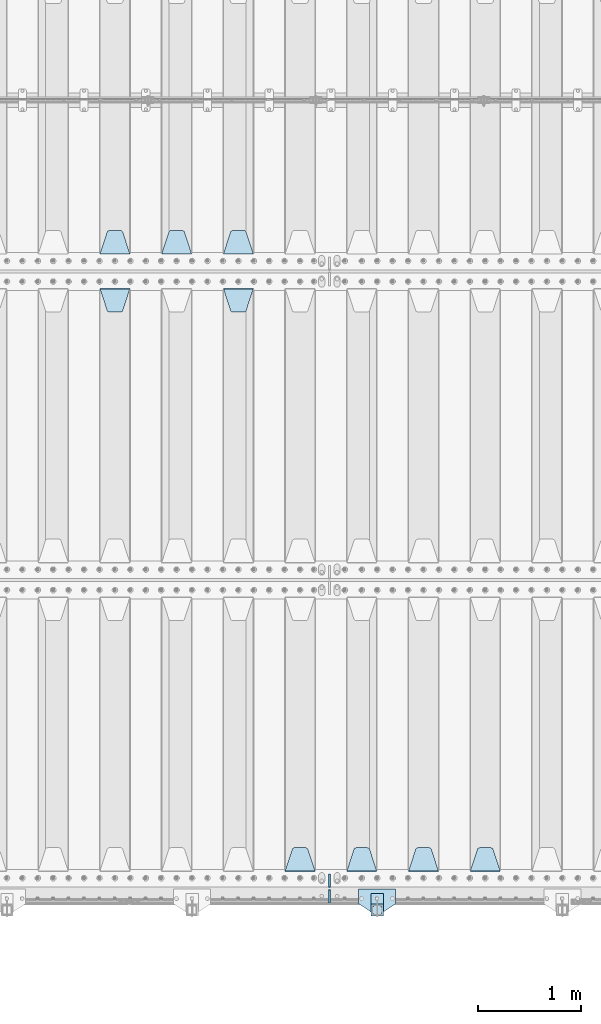
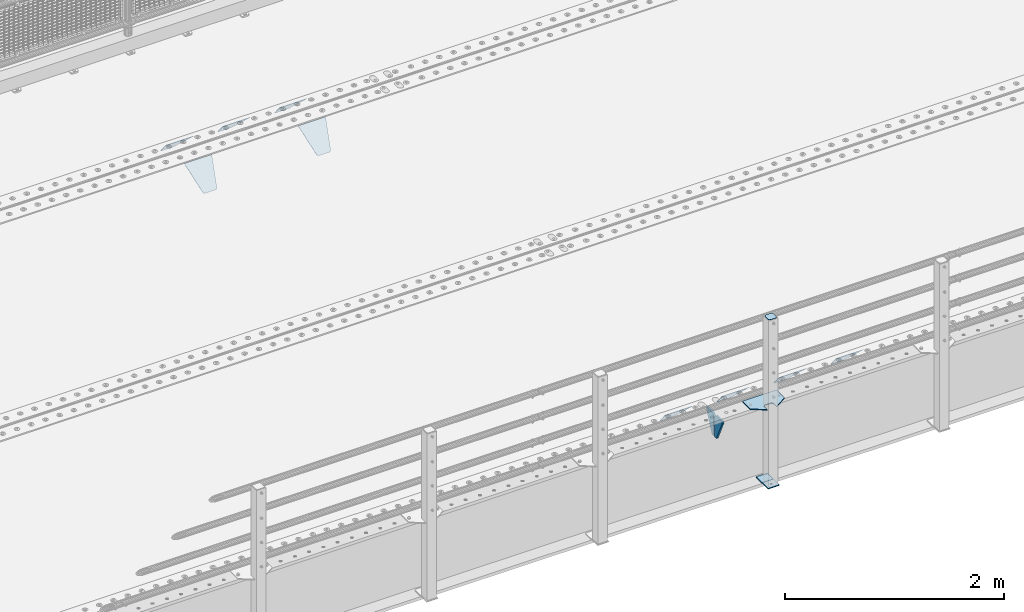
# One storey, part 220 of 270: 15 plates.
"""IFC2X3 building model written with IfcOpenShell, lengths in millimetres."""

from ifc_helpers import new_model, si_unit, frame, origin_with_axes, place, context, subcontext, project, spatial, faceted_brep, material, type_object, element, save


model = new_model("IFC2X3")

# Units and contexts
model_context = context("Model", 3, precision=1e-05, world=origin_with_axes())
body_context = subcontext(model_context, "Body", "Model", "MODEL_VIEW")
ifc_project = project(units=[si_unit("LENGTHUNIT", "METRE", prefix="MILLI"), si_unit("AREAUNIT", "SQUARE_METRE"), si_unit("VOLUMEUNIT", "CUBIC_METRE"), si_unit("MASSUNIT", "GRAM", prefix="KILO"), si_unit("TIMEUNIT", "SECOND"), si_unit("PLANEANGLEUNIT", "RADIAN"), si_unit("SOLIDANGLEUNIT", "STERADIAN"), si_unit("THERMODYNAMICTEMPERATUREUNIT", "DEGREE_CELSIUS"), si_unit("LUMINOUSINTENSITYUNIT", "LUMEN")], contexts=[model_context])

# Site, building, storey
site_placement = place(None, origin_with_axes())
site = spatial("IfcSite", under=ifc_project, at=site_placement, CompositionType="ELEMENT")
building_placement = place(site_placement, origin_with_axes())
building = spatial("IfcBuilding", under=site, at=building_placement, Name="Standard", CompositionType="ELEMENT")
storey_placement = place(building_placement, origin_with_axes())
storey = spatial("IfcBuildingStorey", under=building, at=storey_placement, Name="Undefined", CompositionType="ELEMENT", Elevation=0.0)

# Plates
ifc_material_1 = material(Name="STEEL/S355J2")
plate_type_1 = type_object("IfcPlateType", PredefinedType="NOTDEFINED")
plate_1_placement = place(storey_placement, frame((7930.0, -24005.0, 5.00000000004911), z_axis=(0.0, -1.0, 0.0), x_axis=(-1.0, 0.0, 0.0)))
element("IfcPlate", 1, at=plate_1_placement, inside=storey, type_object=plate_type_1, material=ifc_material_1, context=body_context, shape_type="Brep", body=[
    faceted_brep([(0.0, -5.0, 0.0), (2.31396552408114e-06, -5.0, 145.0), (2.31396552408114e-06, 5.0, 145.0), (0.0, 5.0, 0.0), (130.0, -5.0, 230.0), (130.0, 5.0, 230.0), (130.0, -5.0, 180.0), (130.0, 5.0, 180.0), (130.48036798992, -5.0, 175.122741949597), (130.48036798992, 5.0, 175.122741949597), (131.903011687216, -5.0, 170.432914190873), (131.903011687216, 5.0, 170.432914190873), (134.213259692435, -5.0, 166.11074417451), (134.213259692435, 5.0, 166.11074417451), (137.322330470335, -5.0, 162.322330470337), (137.322330470335, 5.0, 162.322330470337), (141.110744174512, -5.0, 159.213259692437), (141.110744174512, 5.0, 159.213259692437), (145.432914190871, -5.0, 156.903011687218), (145.432914190871, 5.0, 156.903011687218), (150.122741949595, -5.0, 155.48036798992), (150.122741949595, 5.0, 155.48036798992), (155.0, -5.0, 155.0), (155.0, 5.0, 155.0), (205.0, -5.0, 155.0), (205.0, 5.0, 155.0), (209.877258050405, -5.0, 155.48036798992), (209.877258050405, 5.0, 155.48036798992), (214.567085809129, -5.0, 156.903011687218), (214.567085809129, 5.0, 156.903011687218), (218.889255825488, -5.0, 159.213259692437), (218.889255825488, 5.0, 159.213259692437), (222.677669529665, -5.0, 162.322330470337), (222.677669529665, 5.0, 162.322330470337), (225.786740307565, -5.0, 166.11074417451), (225.786740307565, 5.0, 166.11074417451), (228.096988312784, -5.0, 170.432914190873), (228.096988312784, 5.0, 170.432914190873), (229.51963201008, -5.0, 175.122741949597), (229.51963201008, 5.0, 175.122741949597), (230.0, -5.0, 180.0), (230.0, 5.0, 180.0), (230.0, -5.0, 230.0), (230.0, 5.0, 230.0), (360.0, -5.0, 145.0), (360.0, 5.0, 145.0), (360.0, -5.0, -7.27595761418343e-12), (360.0, 5.0, -7.27595761418343e-12)], [[[0, 1, 2, 3]], [[1, 4, 5, 2]], [[4, 6, 7, 5]], [[6, 8, 9, 7]], [[8, 10, 11, 9]], [[10, 12, 13, 11]], [[12, 14, 15, 13]], [[14, 16, 17, 15]], [[16, 18, 19, 17]], [[18, 20, 21, 19]], [[20, 22, 23, 21]], [[22, 24, 25, 23]], [[24, 26, 27, 25]], [[26, 28, 29, 27]], [[28, 30, 31, 29]], [[30, 32, 33, 31]], [[32, 34, 35, 33]], [[34, 36, 37, 35]], [[36, 38, 39, 37]], [[38, 40, 41, 39]], [[40, 42, 43, 41]], [[42, 44, 45, 43]], [[44, 46, 47, 45]], [[46, 0, 3, 47]], [[5, 7, 9, 11, 13, 15, 17, 19, 21, 23, 25, 27, 29, 31, 33, 35, 37, 39, 41, 43, 45, 47, 3, 2]], [[46, 44, 42, 40, 38, 36, 34, 32, 30, 28, 26, 24, 22, 20, 18, 16, 14, 12, 10, 8, 6, 4, 1, 0]]]),
])
plate_type_2 = type_object("IfcPlateType", PredefinedType="NOTDEFINED")
plate_2_placement = place(storey_placement, frame((7809.99999999986, -24050.0000000002, -850.000000000002), z_axis=(0.0, -1.0, 0.0), x_axis=(-1.0, 0.0, 0.0)))
element("IfcPlate", 2, at=plate_2_placement, inside=storey, type_object=plate_type_2, material=ifc_material_1, context=body_context, shape_type="Brep", body=[
    faceted_brep([(53.6360389691836, -5.0, 176.363961030471), (53.6360389691836, 5.0, 176.363961030471), (59.9999999998618, 5.0, 178.999999999793), (59.9999999998618, -5.0, 178.999999999793), (66.3639610305399, 5.0, 176.363961030471), (66.3639610305399, -5.0, 176.363961030471), (68.9999999998618, 5.0, 169.999999999793), (68.9999999998618, -5.0, 169.999999999793), (66.3639610305399, 5.0, 163.636038969114), (66.3639610305399, -5.0, 163.636038969114), (59.9999999998618, 5.0, 160.999999999793), (59.9999999998618, -5.0, 160.999999999793), (53.6360389691836, 5.0, 163.636038969114), (53.6360389691836, -5.0, 163.636038969114), (50.9999999998618, 5.0, 169.999999999793), (50.9999999998618, -5.0, 169.999999999793), (120.0, -5.0, 0.0), (120.0, -5.0, 220.0), (0.0, -5.0, 220.0), (0.0, -5.0, 0.0), (0.0, 5.0, 0.0), (120.0, 5.0, 0.0), (120.0, 5.0, 220.0), (0.0, 5.0, 220.0)], [[[0, 1, 2, 3]], [[3, 2, 4, 5]], [[5, 4, 6, 7]], [[7, 6, 8, 9]], [[9, 8, 10, 11]], [[11, 10, 12, 13]], [[13, 12, 14, 15]], [[15, 14, 1, 0]], [[16, 17, 18, 19], [11, 13, 15, 0, 3, 5, 7, 9]], [[16, 19, 20, 21]], [[17, 16, 21, 22]], [[18, 17, 22, 23]], [[19, 18, 23, 20]], [[22, 21, 20, 23], [2, 1, 14, 12, 10, 8, 6, 4]]]),
])
plate_type_3 = type_object("IfcPlateType", PredefinedType="NOTDEFINED")
plate_3_placement = place(storey_placement, frame((7705.99999999987, -24166.0000000002, 1012.50000000001), z_axis=(0.0, -1.0, 0.0), x_axis=(1.0, 0.0, 0.0)))
element("IfcPlate", 3, at=plate_3_placement, inside=storey, type_object=plate_type_3, material=ifc_material_1, context=body_context, shape_type="Brep", body=[
    faceted_brep([(0.0, -2.5, 19.0), (0.0, -2.5, 69.0), (0.0, 2.5, 69.0), (0.0, 2.5, 19.0), (0.476369668544066, -2.5, 73.2278977451697), (0.476369668544066, 2.5, 73.2278977451697), (1.88159150985302, -2.5, 77.2437910432327), (1.88159150985302, 2.5, 77.2437910432327), (4.14520183310742, -2.5, 80.8463062353167), (4.14520183310742, 2.5, 80.8463062353167), (7.15369376468516, -2.5, 83.8547981668926), (7.15369376468516, 2.5, 83.8547981668926), (10.7562089567655, -2.5, 86.1184084901452), (10.7562089567655, 2.5, 86.1184084901452), (14.7721022548285, -2.5, 87.5236303314541), (14.7721022548285, 2.5, 87.5236303314541), (19.0, -2.5, 88.0), (19.0, 2.5, 88.0), (69.0, -2.5, 88.0), (69.0, 2.5, 88.0), (73.2278977451715, -2.5, 87.5236303314541), (73.2278977451715, 2.5, 87.5236303314541), (77.2437910432345, -2.5, 86.1184084901452), (77.2437910432345, 2.5, 86.1184084901452), (80.8463062353148, -2.5, 83.8547981668926), (80.8463062353148, 2.5, 83.8547981668926), (83.8547981668926, -2.5, 80.8463062353167), (83.8547981668926, 2.5, 80.8463062353167), (86.118408490147, -2.5, 77.2437910432345), (86.118408490147, 2.5, 77.2437910432345), (87.5236303314559, -2.5, 73.2278977451697), (87.5236303314559, 2.5, 73.2278977451697), (88.0, -2.5, 69.0), (88.0, 2.5, 69.0), (88.0, -2.5, 19.0), (88.0, 2.5, 19.0), (87.5236303314559, -2.5, 14.7721022548303), (87.5236303314559, 2.5, 14.7721022548303), (86.118408490147, -2.5, 10.7562089567673), (86.118408490147, 2.5, 10.7562089567673), (83.8547981668926, -2.5, 7.15369376468334), (83.8547981668926, 2.5, 7.15369376468334), (80.8463062353148, -2.5, 4.14520183310742), (80.8463062353148, 2.5, 4.14520183310742), (77.2437910432345, -2.5, 1.88159150985484), (77.2437910432345, 2.5, 1.88159150985484), (73.2278977451715, -2.5, 0.476369668545885), (73.2278977451715, 2.5, 0.476369668545885), (69.0, -2.5, 0.0), (69.0, 2.5, 0.0), (19.0, -2.5, 0.0), (19.0, 2.5, 0.0), (14.7721022548285, -2.5, 0.476369668545885), (14.7721022548285, 2.5, 0.476369668545885), (10.7562089567655, -2.5, 1.88159150985484), (10.7562089567655, 2.5, 1.88159150985484), (7.15369376468516, -2.5, 4.14520183310742), (7.15369376468516, 2.5, 4.14520183310742), (4.14520183310742, -2.5, 7.15369376468334), (4.14520183310742, 2.5, 7.15369376468334), (1.88159150985302, -2.5, 10.7562089567673), (1.88159150985302, 2.5, 10.7562089567673), (0.476369668544066, -2.5, 14.7721022548303), (0.476369668544066, 2.5, 14.7721022548303)], [[[0, 1, 2, 3]], [[1, 4, 5, 2]], [[4, 6, 7, 5]], [[6, 8, 9, 7]], [[8, 10, 11, 9]], [[10, 12, 13, 11]], [[12, 14, 15, 13]], [[14, 16, 17, 15]], [[16, 18, 19, 17]], [[18, 20, 21, 19]], [[20, 22, 23, 21]], [[22, 24, 25, 23]], [[24, 26, 27, 25]], [[26, 28, 29, 27]], [[28, 30, 31, 29]], [[30, 32, 33, 31]], [[32, 34, 35, 33]], [[34, 36, 37, 35]], [[36, 38, 39, 37]], [[38, 40, 41, 39]], [[40, 42, 43, 41]], [[42, 44, 45, 43]], [[44, 46, 47, 45]], [[46, 48, 49, 47]], [[48, 50, 51, 49]], [[50, 52, 53, 51]], [[52, 54, 55, 53]], [[54, 56, 57, 55]], [[56, 58, 59, 57]], [[58, 60, 61, 59]], [[60, 62, 63, 61]], [[62, 0, 3, 63]], [[5, 7, 9, 11, 13, 15, 17, 19, 21, 23, 25, 27, 29, 31, 33, 35, 37, 39, 41, 43, 45, 47, 49, 51, 53, 55, 57, 59, 61, 63, 3, 2]], [[62, 60, 58, 56, 54, 52, 50, 48, 46, 44, 42, 40, 38, 36, 34, 32, 30, 28, 26, 24, 22, 20, 18, 16, 14, 12, 10, 8, 6, 4, 1, 0]]]),
])
plate_type_4 = type_object("IfcPlateType", PredefinedType="NOTDEFINED")
plate_4_placement = place(storey_placement, frame((7809.99999999986, -24050.0000000002, -857.500000000002), z_axis=(0.0, -1.0, 0.0), x_axis=(-1.0, 0.0, 0.0)))
element("IfcPlate", 4, at=plate_4_placement, inside=storey, type_object=plate_type_4, material=ifc_material_1, context=body_context, shape_type="Brep", body=[
    faceted_brep([(0.0, -2.5, 0.0), (0.0, -2.5, 100.0), (0.0, 2.5, 100.0), (0.0, 2.5, 0.0), (120.0, -2.5, 100.0), (120.0, 2.5, 100.0), (120.0, -2.5, 0.0), (120.0, 2.5, 0.0)], [[[0, 1, 2, 3]], [[1, 4, 5, 2]], [[4, 6, 7, 5]], [[6, 0, 3, 7]], [[5, 7, 3, 2]], [[6, 4, 1, 0]]]),
])
ifc_material_2 = material(Name="STEEL/S355N")
plate_type_5 = type_object("IfcPlateType", PredefinedType="NOTDEFINED")
plate_5_placement = place(storey_placement, frame((6545.0, -17831.767766953, -1.76776695296758), z_axis=(0.0, 0.707106781186547, -0.707106781186548), x_axis=(-1.0, 0.0, 0.0)))
element("IfcPlate", 5, at=plate_5_placement, inside=storey, type_object=plate_type_5, material=ifc_material_2, context=body_context, shape_type="Brep", body=[
    faceted_brep([(0.0, -2.5, 0.0), (69.345504679477, -2.5, 300.171731424831), (69.345504679477, 2.5, 300.171731424831), (0.0, 2.5, 0.0), (70.9274061199576, -2.5, 304.8974424154), (70.9274061199576, 2.5, 304.8974424154), (73.3818627772307, -2.49999999999818, 309.234538108527), (73.3818627772307, 2.50000000000182, 309.234538108527), (76.6187032999551, -2.5, 313.023683126103), (76.6187032999551, 2.5, 313.023683126103), (80.5190132704993, -2.5, 316.125672595372), (80.5190132704993, 2.50000000000182, 316.125672595372), (84.9395038596849, -2.49999999999818, 318.426546230476), (84.9395038596849, 2.5, 318.426546230476), (89.7177759439219, -2.49999999999818, 319.841774983275), (89.7177759439219, 2.50000000000182, 319.841774983275), (94.678286292652, -2.5, 320.319366455078), (94.678286292652, 2.5, 320.319366455078), (195.321713707348, -2.5, 320.319366455078), (195.321713707348, 2.5, 320.319366455078), (200.282224056078, -2.49999999999818, 319.841774983275), (200.282224056078, 2.50000000000182, 319.841774983275), (205.060496140315, -2.5, 318.426546230476), (205.060496140315, 2.5, 318.426546230476), (209.480986729501, -2.5, 316.12567259537), (209.480986729501, 2.50000000000182, 316.12567259537), (213.381296700045, -2.5, 313.023683126103), (213.381296700045, 2.5, 313.023683126103), (216.618137222769, -2.49999999999818, 309.234538108525), (216.618137222769, 2.50000000000182, 309.234538108527), (219.072593880042, -2.49999999999818, 304.897442415398), (219.072593880042, 2.50000000000182, 304.897442415397), (220.654495320523, -2.5, 300.171731424831), (220.654495320523, 2.5, 300.171731424831), (290.0, -2.49999999999818, 0.0), (290.0, 2.5, 0.0)], [[[0, 1, 2, 3]], [[1, 4, 5, 2]], [[4, 6, 7, 5]], [[6, 8, 9, 7]], [[8, 10, 11, 9]], [[10, 12, 13, 11]], [[12, 14, 15, 13]], [[14, 16, 17, 15]], [[16, 18, 19, 17]], [[18, 20, 21, 19]], [[20, 22, 23, 21]], [[22, 24, 25, 23]], [[24, 26, 27, 25]], [[26, 28, 29, 27]], [[28, 30, 31, 29]], [[30, 32, 33, 31]], [[32, 34, 35, 33]], [[34, 0, 3, 35]], [[5, 7, 9, 11, 13, 15, 17, 19, 21, 23, 25, 27, 29, 31, 33, 35, 3, 2]], [[34, 32, 30, 28, 26, 24, 22, 20, 18, 16, 14, 12, 10, 8, 6, 4, 1, 0]]]),
])
plate_6_placement = place(storey_placement, frame((5945.0, -17831.767766953, -1.76776695296758), z_axis=(0.0, 0.707106781186547, -0.707106781186548), x_axis=(-1.0, 0.0, 0.0)))
element("IfcPlate", 6, at=plate_6_placement, inside=storey, type_object=plate_type_5, material=ifc_material_2, context=body_context, shape_type="Brep", body=[
    faceted_brep([(0.0, -2.5, 0.0), (69.345504679477, -2.5, 300.171731424831), (69.345504679477, 2.5, 300.171731424831), (0.0, 2.5, 0.0), (70.9274061199576, -2.5, 304.8974424154), (70.9274061199576, 2.5, 304.8974424154), (73.3818627772307, -2.49999999999818, 309.234538108527), (73.3818627772307, 2.50000000000182, 309.234538108527), (76.6187032999551, -2.5, 313.023683126103), (76.6187032999551, 2.5, 313.023683126103), (80.5190132704993, -2.5, 316.125672595372), (80.5190132704993, 2.50000000000182, 316.125672595372), (84.9395038596849, -2.49999999999818, 318.426546230476), (84.9395038596849, 2.5, 318.426546230476), (89.7177759439219, -2.49999999999818, 319.841774983275), (89.7177759439219, 2.50000000000182, 319.841774983275), (94.678286292652, -2.5, 320.319366455078), (94.678286292652, 2.5, 320.319366455078), (195.321713707348, -2.5, 320.319366455078), (195.321713707348, 2.5, 320.319366455078), (200.282224056078, -2.49999999999818, 319.841774983275), (200.282224056078, 2.50000000000182, 319.841774983275), (205.060496140315, -2.5, 318.426546230476), (205.060496140315, 2.5, 318.426546230476), (209.480986729501, -2.5, 316.12567259537), (209.480986729501, 2.50000000000182, 316.12567259537), (213.381296700045, -2.5, 313.023683126103), (213.381296700045, 2.5, 313.023683126103), (216.618137222769, -2.49999999999818, 309.234538108525), (216.618137222769, 2.50000000000182, 309.234538108527), (219.072593880042, -2.49999999999818, 304.897442415398), (219.072593880042, 2.50000000000182, 304.897442415397), (220.654495320523, -2.5, 300.171731424831), (220.654495320523, 2.5, 300.171731424831), (290.0, -2.49999999999818, 0.0), (290.0, 2.5, 0.0)], [[[0, 1, 2, 3]], [[1, 4, 5, 2]], [[4, 6, 7, 5]], [[6, 8, 9, 7]], [[8, 10, 11, 9]], [[10, 12, 13, 11]], [[12, 14, 15, 13]], [[14, 16, 17, 15]], [[16, 18, 19, 17]], [[18, 20, 21, 19]], [[20, 22, 23, 21]], [[22, 24, 25, 23]], [[24, 26, 27, 25]], [[26, 28, 29, 27]], [[28, 30, 31, 29]], [[30, 32, 33, 31]], [[32, 34, 35, 33]], [[34, 0, 3, 35]], [[5, 7, 9, 11, 13, 15, 17, 19, 21, 23, 25, 27, 29, 31, 33, 35, 3, 2]], [[34, 32, 30, 28, 26, 24, 22, 20, 18, 16, 14, 12, 10, 8, 6, 4, 1, 0]]]),
])
plate_7_placement = place(storey_placement, frame((5345.0, -17831.767766953, -1.76776695296758), z_axis=(0.0, 0.707106781186547, -0.707106781186548), x_axis=(-1.0, 0.0, 0.0)))
element("IfcPlate", 7, at=plate_7_placement, inside=storey, type_object=plate_type_5, material=ifc_material_2, context=body_context, shape_type="Brep", body=[
    faceted_brep([(0.0, -2.5, 0.0), (69.345504679477, -2.5, 300.171731424831), (69.345504679477, 2.5, 300.171731424831), (0.0, 2.5, 0.0), (70.9274061199576, -2.5, 304.8974424154), (70.9274061199576, 2.5, 304.8974424154), (73.3818627772307, -2.49999999999818, 309.234538108527), (73.3818627772307, 2.50000000000182, 309.234538108527), (76.6187032999551, -2.5, 313.023683126103), (76.6187032999551, 2.5, 313.023683126103), (80.5190132704993, -2.5, 316.125672595372), (80.5190132704993, 2.50000000000182, 316.125672595372), (84.9395038596849, -2.49999999999818, 318.426546230476), (84.9395038596849, 2.5, 318.426546230476), (89.7177759439219, -2.49999999999818, 319.841774983275), (89.7177759439219, 2.50000000000182, 319.841774983275), (94.678286292652, -2.5, 320.319366455078), (94.678286292652, 2.5, 320.319366455078), (195.321713707348, -2.5, 320.319366455078), (195.321713707348, 2.5, 320.319366455078), (200.282224056078, -2.49999999999818, 319.841774983275), (200.282224056078, 2.50000000000182, 319.841774983275), (205.060496140315, -2.5, 318.426546230476), (205.060496140315, 2.5, 318.426546230476), (209.480986729501, -2.5, 316.12567259537), (209.480986729501, 2.50000000000182, 316.12567259537), (213.381296700045, -2.5, 313.023683126103), (213.381296700045, 2.5, 313.023683126103), (216.618137222769, -2.49999999999818, 309.234538108525), (216.618137222769, 2.50000000000182, 309.234538108527), (219.072593880042, -2.49999999999818, 304.897442415398), (219.072593880042, 2.50000000000182, 304.897442415397), (220.654495320523, -2.5, 300.171731424831), (220.654495320523, 2.5, 300.171731424831), (290.0, -2.49999999999818, 0.0), (290.0, 2.5, 0.0)], [[[0, 1, 2, 3]], [[1, 4, 5, 2]], [[4, 6, 7, 5]], [[6, 8, 9, 7]], [[8, 10, 11, 9]], [[10, 12, 13, 11]], [[12, 14, 15, 13]], [[14, 16, 17, 15]], [[16, 18, 19, 17]], [[18, 20, 21, 19]], [[20, 22, 23, 21]], [[22, 24, 25, 23]], [[24, 26, 27, 25]], [[26, 28, 29, 27]], [[28, 30, 31, 29]], [[30, 32, 33, 31]], [[32, 34, 35, 33]], [[34, 0, 3, 35]], [[5, 7, 9, 11, 13, 15, 17, 19, 21, 23, 25, 27, 29, 31, 33, 35, 3, 2]], [[34, 32, 30, 28, 26, 24, 22, 20, 18, 16, 14, 12, 10, 8, 6, 4, 1, 0]]]),
])
plate_8_placement = place(storey_placement, frame((6255.0, -18168.232233044, -1.76776695296576), z_axis=(0.0, -0.707106781186548, -0.707106781186547), x_axis=(1.0, 0.0, 0.0)))
element("IfcPlate", 8, at=plate_8_placement, inside=storey, type_object=plate_type_5, material=ifc_material_2, context=body_context, shape_type="Brep", body=[
    faceted_brep([(0.0, -2.5, 0.0), (69.345504679477, -2.5, 300.171731424831), (69.345504679477, 2.5, 300.171731424831), (0.0, 2.5, 0.0), (70.9274061199576, -2.5, 304.8974424154), (70.9274061199576, 2.5, 304.8974424154), (73.3818627772307, -2.49999999999818, 309.234538108527), (73.3818627772307, 2.50000000000182, 309.234538108527), (76.6187032999551, -2.5, 313.023683126103), (76.6187032999551, 2.5, 313.023683126103), (80.5190132704993, -2.5, 316.125672595372), (80.5190132704993, 2.50000000000182, 316.125672595372), (84.9395038596849, -2.49999999999818, 318.426546230476), (84.9395038596849, 2.5, 318.426546230476), (89.7177759439219, -2.49999999999818, 319.841774983275), (89.7177759439219, 2.50000000000182, 319.841774983275), (94.678286292652, -2.5, 320.319366455078), (94.678286292652, 2.5, 320.319366455078), (195.321713707348, -2.5, 320.319366455078), (195.321713707348, 2.5, 320.319366455078), (200.282224056078, -2.49999999999818, 319.841774983275), (200.282224056078, 2.50000000000182, 319.841774983275), (205.060496140315, -2.5, 318.426546230476), (205.060496140315, 2.5, 318.426546230476), (209.480986729501, -2.5, 316.12567259537), (209.480986729501, 2.50000000000182, 316.12567259537), (213.381296700045, -2.5, 313.023683126103), (213.381296700045, 2.5, 313.023683126103), (216.618137222769, -2.49999999999818, 309.234538108525), (216.618137222769, 2.50000000000182, 309.234538108527), (219.072593880042, -2.49999999999818, 304.897442415398), (219.072593880042, 2.50000000000182, 304.897442415397), (220.654495320523, -2.5, 300.171731424831), (220.654495320523, 2.5, 300.171731424831), (290.0, -2.49999999999818, 0.0), (290.0, 2.5, 0.0)], [[[0, 1, 2, 3]], [[1, 4, 5, 2]], [[4, 6, 7, 5]], [[6, 8, 9, 7]], [[8, 10, 11, 9]], [[10, 12, 13, 11]], [[12, 14, 15, 13]], [[14, 16, 17, 15]], [[16, 18, 19, 17]], [[18, 20, 21, 19]], [[20, 22, 23, 21]], [[22, 24, 25, 23]], [[24, 26, 27, 25]], [[26, 28, 29, 27]], [[28, 30, 31, 29]], [[30, 32, 33, 31]], [[32, 34, 35, 33]], [[34, 0, 3, 35]], [[5, 7, 9, 11, 13, 15, 17, 19, 21, 23, 25, 27, 29, 31, 33, 35, 3, 2]], [[34, 32, 30, 28, 26, 24, 22, 20, 18, 16, 14, 12, 10, 8, 6, 4, 1, 0]]]),
])
plate_9_placement = place(storey_placement, frame((5055.0, -18168.232233044, -1.76776695296576), z_axis=(0.0, -0.707106781186548, -0.707106781186547), x_axis=(1.0, 0.0, 0.0)))
element("IfcPlate", 9, at=plate_9_placement, inside=storey, type_object=plate_type_5, material=ifc_material_2, context=body_context, shape_type="Brep", body=[
    faceted_brep([(0.0, -2.5, 0.0), (69.345504679477, -2.5, 300.171731424831), (69.345504679477, 2.5, 300.171731424831), (0.0, 2.5, 0.0), (70.9274061199576, -2.5, 304.8974424154), (70.9274061199576, 2.5, 304.8974424154), (73.3818627772307, -2.49999999999818, 309.234538108527), (73.3818627772307, 2.50000000000182, 309.234538108527), (76.6187032999551, -2.5, 313.023683126103), (76.6187032999551, 2.5, 313.023683126103), (80.5190132704993, -2.5, 316.125672595372), (80.5190132704993, 2.50000000000182, 316.125672595372), (84.9395038596849, -2.49999999999818, 318.426546230476), (84.9395038596849, 2.5, 318.426546230476), (89.7177759439219, -2.49999999999818, 319.841774983275), (89.7177759439219, 2.50000000000182, 319.841774983275), (94.678286292652, -2.5, 320.319366455078), (94.678286292652, 2.5, 320.319366455078), (195.321713707348, -2.5, 320.319366455078), (195.321713707348, 2.5, 320.319366455078), (200.282224056078, -2.49999999999818, 319.841774983275), (200.282224056078, 2.50000000000182, 319.841774983275), (205.060496140315, -2.5, 318.426546230476), (205.060496140315, 2.5, 318.426546230476), (209.480986729501, -2.5, 316.12567259537), (209.480986729501, 2.50000000000182, 316.12567259537), (213.381296700045, -2.5, 313.023683126103), (213.381296700045, 2.5, 313.023683126103), (216.618137222769, -2.49999999999818, 309.234538108525), (216.618137222769, 2.50000000000182, 309.234538108527), (219.072593880042, -2.49999999999818, 304.897442415398), (219.072593880042, 2.50000000000182, 304.897442415397), (220.654495320523, -2.5, 300.171731424831), (220.654495320523, 2.5, 300.171731424831), (290.0, -2.49999999999818, 0.0), (290.0, 2.5, 0.0)], [[[0, 1, 2, 3]], [[1, 4, 5, 2]], [[4, 6, 7, 5]], [[6, 8, 9, 7]], [[8, 10, 11, 9]], [[10, 12, 13, 11]], [[12, 14, 15, 13]], [[14, 16, 17, 15]], [[16, 18, 19, 17]], [[18, 20, 21, 19]], [[20, 22, 23, 21]], [[22, 24, 25, 23]], [[24, 26, 27, 25]], [[26, 28, 29, 27]], [[28, 30, 31, 29]], [[30, 32, 33, 31]], [[32, 34, 35, 33]], [[34, 0, 3, 35]], [[5, 7, 9, 11, 13, 15, 17, 19, 21, 23, 25, 27, 29, 31, 33, 35, 3, 2]], [[34, 32, 30, 28, 26, 24, 22, 20, 18, 16, 14, 12, 10, 8, 6, 4, 1, 0]]]),
])
plate_10_placement = place(storey_placement, frame((8945.0, -23831.767766953, -1.76776695296758), z_axis=(0.0, 0.707106781186547, -0.707106781186548), x_axis=(-1.0, 0.0, 0.0)))
element("IfcPlate", 10, at=plate_10_placement, inside=storey, type_object=plate_type_5, material=ifc_material_2, context=body_context, shape_type="Brep", body=[
    faceted_brep([(0.0, -2.5, 0.0), (69.345504679477, -2.5, 300.171731424831), (69.345504679477, 2.5, 300.171731424831), (0.0, 2.5, 0.0), (70.9274061199576, -2.5, 304.8974424154), (70.9274061199576, 2.5, 304.8974424154), (73.3818627772307, -2.49999999999818, 309.234538108527), (73.3818627772307, 2.50000000000182, 309.234538108527), (76.6187032999551, -2.5, 313.023683126103), (76.6187032999551, 2.5, 313.023683126103), (80.5190132704993, -2.5, 316.125672595372), (80.5190132704993, 2.50000000000182, 316.125672595372), (84.9395038596849, -2.49999999999818, 318.426546230476), (84.9395038596849, 2.5, 318.426546230476), (89.7177759439219, -2.49999999999818, 319.841774983275), (89.7177759439219, 2.50000000000182, 319.841774983275), (94.678286292652, -2.5, 320.319366455078), (94.678286292652, 2.5, 320.319366455078), (195.321713707348, -2.5, 320.319366455078), (195.321713707348, 2.5, 320.319366455078), (200.282224056078, -2.49999999999818, 319.841774983275), (200.282224056078, 2.50000000000182, 319.841774983275), (205.060496140315, -2.5, 318.426546230476), (205.060496140315, 2.5, 318.426546230476), (209.480986729501, -2.5, 316.12567259537), (209.480986729501, 2.50000000000182, 316.12567259537), (213.381296700045, -2.5, 313.023683126103), (213.381296700045, 2.5, 313.023683126103), (216.618137222769, -2.49999999999818, 309.234538108525), (216.618137222769, 2.50000000000182, 309.234538108527), (219.072593880042, -2.49999999999818, 304.897442415398), (219.072593880042, 2.50000000000182, 304.897442415397), (220.654495320523, -2.5, 300.171731424831), (220.654495320523, 2.5, 300.171731424831), (290.0, -2.49999999999818, 0.0), (290.0, 2.5, 0.0)], [[[0, 1, 2, 3]], [[1, 4, 5, 2]], [[4, 6, 7, 5]], [[6, 8, 9, 7]], [[8, 10, 11, 9]], [[10, 12, 13, 11]], [[12, 14, 15, 13]], [[14, 16, 17, 15]], [[16, 18, 19, 17]], [[18, 20, 21, 19]], [[20, 22, 23, 21]], [[22, 24, 25, 23]], [[24, 26, 27, 25]], [[26, 28, 29, 27]], [[28, 30, 31, 29]], [[30, 32, 33, 31]], [[32, 34, 35, 33]], [[34, 0, 3, 35]], [[5, 7, 9, 11, 13, 15, 17, 19, 21, 23, 25, 27, 29, 31, 33, 35, 3, 2]], [[34, 32, 30, 28, 26, 24, 22, 20, 18, 16, 14, 12, 10, 8, 6, 4, 1, 0]]]),
])
plate_11_placement = place(storey_placement, frame((8345.0, -23831.767766953, -1.76776695296758), z_axis=(0.0, 0.707106781186547, -0.707106781186548), x_axis=(-1.0, 0.0, 0.0)))
element("IfcPlate", 11, at=plate_11_placement, inside=storey, type_object=plate_type_5, material=ifc_material_2, context=body_context, shape_type="Brep", body=[
    faceted_brep([(0.0, -2.5, 0.0), (69.345504679477, -2.5, 300.171731424831), (69.345504679477, 2.5, 300.171731424831), (0.0, 2.5, 0.0), (70.9274061199576, -2.5, 304.8974424154), (70.9274061199576, 2.5, 304.8974424154), (73.3818627772307, -2.49999999999818, 309.234538108527), (73.3818627772307, 2.50000000000182, 309.234538108527), (76.6187032999551, -2.5, 313.023683126103), (76.6187032999551, 2.5, 313.023683126103), (80.5190132704993, -2.5, 316.125672595372), (80.5190132704993, 2.50000000000182, 316.125672595372), (84.9395038596849, -2.49999999999818, 318.426546230476), (84.9395038596849, 2.5, 318.426546230476), (89.7177759439219, -2.49999999999818, 319.841774983275), (89.7177759439219, 2.50000000000182, 319.841774983275), (94.678286292652, -2.5, 320.319366455078), (94.678286292652, 2.5, 320.319366455078), (195.321713707348, -2.5, 320.319366455078), (195.321713707348, 2.5, 320.319366455078), (200.282224056078, -2.49999999999818, 319.841774983275), (200.282224056078, 2.50000000000182, 319.841774983275), (205.060496140315, -2.5, 318.426546230476), (205.060496140315, 2.5, 318.426546230476), (209.480986729501, -2.5, 316.12567259537), (209.480986729501, 2.50000000000182, 316.12567259537), (213.381296700045, -2.5, 313.023683126103), (213.381296700045, 2.5, 313.023683126103), (216.618137222769, -2.49999999999818, 309.234538108525), (216.618137222769, 2.50000000000182, 309.234538108527), (219.072593880042, -2.49999999999818, 304.897442415398), (219.072593880042, 2.50000000000182, 304.897442415397), (220.654495320523, -2.5, 300.171731424831), (220.654495320523, 2.5, 300.171731424831), (290.0, -2.49999999999818, 0.0), (290.0, 2.5, 0.0)], [[[0, 1, 2, 3]], [[1, 4, 5, 2]], [[4, 6, 7, 5]], [[6, 8, 9, 7]], [[8, 10, 11, 9]], [[10, 12, 13, 11]], [[12, 14, 15, 13]], [[14, 16, 17, 15]], [[16, 18, 19, 17]], [[18, 20, 21, 19]], [[20, 22, 23, 21]], [[22, 24, 25, 23]], [[24, 26, 27, 25]], [[26, 28, 29, 27]], [[28, 30, 31, 29]], [[30, 32, 33, 31]], [[32, 34, 35, 33]], [[34, 0, 3, 35]], [[5, 7, 9, 11, 13, 15, 17, 19, 21, 23, 25, 27, 29, 31, 33, 35, 3, 2]], [[34, 32, 30, 28, 26, 24, 22, 20, 18, 16, 14, 12, 10, 8, 6, 4, 1, 0]]]),
])
plate_12_placement = place(storey_placement, frame((7745.0, -23831.767766953, -1.76776695296758), z_axis=(0.0, 0.707106781186547, -0.707106781186548), x_axis=(-1.0, 0.0, 0.0)))
element("IfcPlate", 12, at=plate_12_placement, inside=storey, type_object=plate_type_5, material=ifc_material_2, context=body_context, shape_type="Brep", body=[
    faceted_brep([(0.0, -2.5, 0.0), (69.345504679477, -2.5, 300.171731424831), (69.345504679477, 2.5, 300.171731424831), (0.0, 2.5, 0.0), (70.9274061199576, -2.5, 304.8974424154), (70.9274061199576, 2.5, 304.8974424154), (73.3818627772307, -2.49999999999818, 309.234538108527), (73.3818627772307, 2.50000000000182, 309.234538108527), (76.6187032999551, -2.5, 313.023683126103), (76.6187032999551, 2.5, 313.023683126103), (80.5190132704993, -2.5, 316.125672595372), (80.5190132704993, 2.50000000000182, 316.125672595372), (84.9395038596849, -2.49999999999818, 318.426546230476), (84.9395038596849, 2.5, 318.426546230476), (89.7177759439219, -2.49999999999818, 319.841774983275), (89.7177759439219, 2.50000000000182, 319.841774983275), (94.678286292652, -2.5, 320.319366455078), (94.678286292652, 2.5, 320.319366455078), (195.321713707348, -2.5, 320.319366455078), (195.321713707348, 2.5, 320.319366455078), (200.282224056078, -2.49999999999818, 319.841774983275), (200.282224056078, 2.50000000000182, 319.841774983275), (205.060496140315, -2.5, 318.426546230476), (205.060496140315, 2.5, 318.426546230476), (209.480986729501, -2.5, 316.12567259537), (209.480986729501, 2.50000000000182, 316.12567259537), (213.381296700045, -2.5, 313.023683126103), (213.381296700045, 2.5, 313.023683126103), (216.618137222769, -2.49999999999818, 309.234538108525), (216.618137222769, 2.50000000000182, 309.234538108527), (219.072593880042, -2.49999999999818, 304.897442415398), (219.072593880042, 2.50000000000182, 304.897442415397), (220.654495320523, -2.5, 300.171731424831), (220.654495320523, 2.5, 300.171731424831), (290.0, -2.49999999999818, 0.0), (290.0, 2.5, 0.0)], [[[0, 1, 2, 3]], [[1, 4, 5, 2]], [[4, 6, 7, 5]], [[6, 8, 9, 7]], [[8, 10, 11, 9]], [[10, 12, 13, 11]], [[12, 14, 15, 13]], [[14, 16, 17, 15]], [[16, 18, 19, 17]], [[18, 20, 21, 19]], [[20, 22, 23, 21]], [[22, 24, 25, 23]], [[24, 26, 27, 25]], [[26, 28, 29, 27]], [[28, 30, 31, 29]], [[30, 32, 33, 31]], [[32, 34, 35, 33]], [[34, 0, 3, 35]], [[5, 7, 9, 11, 13, 15, 17, 19, 21, 23, 25, 27, 29, 31, 33, 35, 3, 2]], [[34, 32, 30, 28, 26, 24, 22, 20, 18, 16, 14, 12, 10, 8, 6, 4, 1, 0]]]),
])
plate_13_placement = place(storey_placement, frame((7145.0, -23831.767766953, -1.76776695296758), z_axis=(0.0, 0.707106781186547, -0.707106781186548), x_axis=(-1.0, 0.0, 0.0)))
element("IfcPlate", 13, at=plate_13_placement, inside=storey, type_object=plate_type_5, material=ifc_material_2, context=body_context, shape_type="Brep", body=[
    faceted_brep([(0.0, -2.5, 0.0), (69.345504679477, -2.5, 300.171731424831), (69.345504679477, 2.5, 300.171731424831), (0.0, 2.5, 0.0), (70.9274061199576, -2.5, 304.8974424154), (70.9274061199576, 2.5, 304.8974424154), (73.3818627772307, -2.49999999999818, 309.234538108527), (73.3818627772307, 2.50000000000182, 309.234538108527), (76.6187032999551, -2.5, 313.023683126103), (76.6187032999551, 2.5, 313.023683126103), (80.5190132704993, -2.5, 316.125672595372), (80.5190132704993, 2.50000000000182, 316.125672595372), (84.9395038596849, -2.49999999999818, 318.426546230476), (84.9395038596849, 2.5, 318.426546230476), (89.7177759439219, -2.49999999999818, 319.841774983275), (89.7177759439219, 2.50000000000182, 319.841774983275), (94.678286292652, -2.5, 320.319366455078), (94.678286292652, 2.5, 320.319366455078), (195.321713707348, -2.5, 320.319366455078), (195.321713707348, 2.5, 320.319366455078), (200.282224056078, -2.49999999999818, 319.841774983275), (200.282224056078, 2.50000000000182, 319.841774983275), (205.060496140315, -2.5, 318.426546230476), (205.060496140315, 2.5, 318.426546230476), (209.480986729501, -2.5, 316.12567259537), (209.480986729501, 2.50000000000182, 316.12567259537), (213.381296700045, -2.5, 313.023683126103), (213.381296700045, 2.5, 313.023683126103), (216.618137222769, -2.49999999999818, 309.234538108525), (216.618137222769, 2.50000000000182, 309.234538108527), (219.072593880042, -2.49999999999818, 304.897442415398), (219.072593880042, 2.50000000000182, 304.897442415397), (220.654495320523, -2.5, 300.171731424831), (220.654495320523, 2.5, 300.171731424831), (290.0, -2.49999999999818, 0.0), (290.0, 2.5, 0.0)], [[[0, 1, 2, 3]], [[1, 4, 5, 2]], [[4, 6, 7, 5]], [[6, 8, 9, 7]], [[8, 10, 11, 9]], [[10, 12, 13, 11]], [[12, 14, 15, 13]], [[14, 16, 17, 15]], [[16, 18, 19, 17]], [[18, 20, 21, 19]], [[20, 22, 23, 21]], [[22, 24, 25, 23]], [[24, 26, 27, 25]], [[26, 28, 29, 27]], [[28, 30, 31, 29]], [[30, 32, 33, 31]], [[32, 34, 35, 33]], [[34, 0, 3, 35]], [[5, 7, 9, 11, 13, 15, 17, 19, 21, 23, 25, 27, 29, 31, 33, 35, 3, 2]], [[34, 32, 30, 28, 26, 24, 22, 20, 18, 16, 14, 12, 10, 8, 6, 4, 1, 0]]]),
])
plate_type_6 = type_object("IfcPlateType", PredefinedType="NOTDEFINED")
for number, where, z_axis, x_axis in (
    (14, (7285.0, -23858.75, -35.0), (0.0, 0.0, -1.0), (0.0, -1.0, 0.0)),
    (15, (7285.0, -24141.25, -35.0), (0.0, 0.0, -1.0), (0.0, 1.0, 0.0)),
):
    element("IfcPlate", number, at=place(storey_placement, frame(where, z_axis=z_axis, x_axis=x_axis)), inside=storey, type_object=plate_type_6, material=ifc_material_2, context=body_context, shape_type="Brep", body=[
        faceted_brep([(0.0, -10.0, 0.0), (0.0, -10.0, 30.0), (0.0, 10.0, 30.0), (0.0, 10.0, 0.0), (102.0, -10.0, 250.0), (102.0, 10.0, 250.0), (132.0, -10.0, 250.0), (132.0, 10.0, 250.0), (132.0, -10.0, 30.0), (132.0, 10.0, 30.0), (131.544232590368, -10.0, 24.790554669992), (131.544232590368, 10.0, 24.790554669992), (130.190778623579, -10.0, 19.7393957002299), (130.190778623579, 10.0, 19.7393957002299), (127.980762113533, -10.0, 15.0), (127.980762113533, 10.0, 15.0), (124.98133329357, -10.0, 10.7163717094038), (124.98133329357, 10.0, 10.7163717094038), (121.283628290596, -10.0, 7.01866670643062), (121.283628290596, 10.0, 7.01866670643062), (117.0, -10.0, 4.01923788646684), (117.0, 10.0, 4.01923788646684), (112.260604299769, -10.0, 1.80922137642278), (112.260604299769, 10.0, 1.80922137642278), (107.209445330009, -10.0, 0.455767409633722), (107.209445330009, 10.0, 0.455767409633722), (102.0, -10.0, 0.0), (102.0, 10.0, 0.0)], [[[0, 1, 2, 3]], [[1, 4, 5, 2]], [[4, 6, 7, 5]], [[6, 8, 9, 7]], [[8, 10, 11, 9]], [[10, 12, 13, 11]], [[12, 14, 15, 13]], [[14, 16, 17, 15]], [[16, 18, 19, 17]], [[18, 20, 21, 19]], [[20, 22, 23, 21]], [[22, 24, 25, 23]], [[24, 26, 27, 25]], [[26, 0, 3, 27]], [[5, 7, 9, 11, 13, 15, 17, 19, 21, 23, 25, 27, 3, 2]], [[26, 24, 22, 20, 18, 16, 14, 12, 10, 8, 6, 4, 1, 0]]]),
    ])

save(model, "model.ifc")
